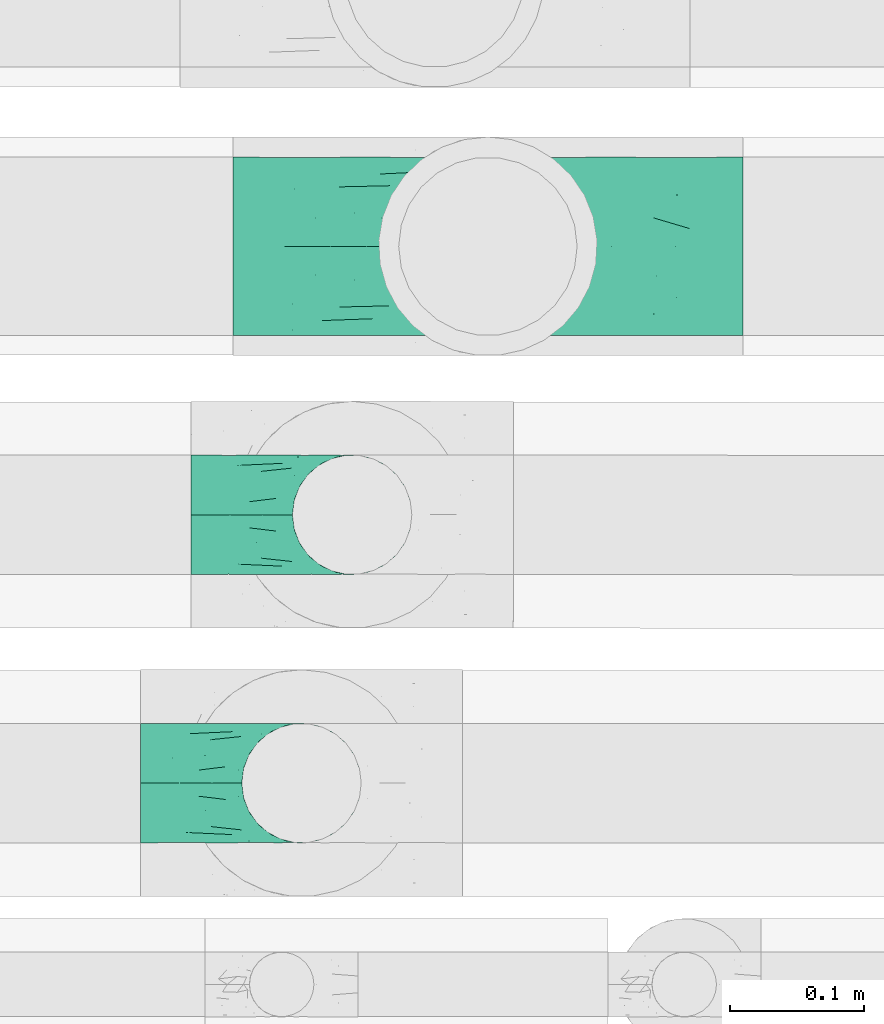
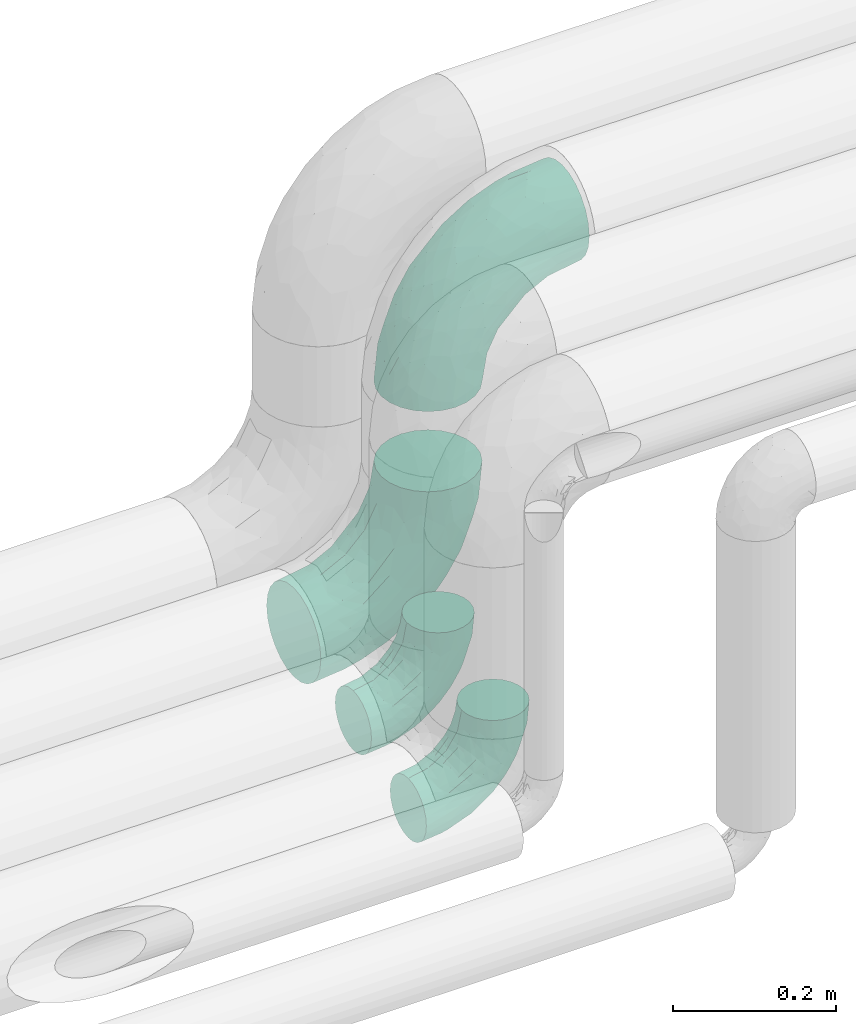
# One storey, part 58 of 93: 4 flow fittings.
"""IFC2X3 building model written with IfcOpenShell, lengths in millimetres."""

from ifc_helpers import new_model, entity, si_unit, converted_unit, derived_unit, direction, frame, origin, place, context, subcontext, project, spatial, faceted_brep, source, transform, mapped, material, type_object, type_shapes, element, save


model = new_model("IFC2X3")

# Units and contexts
model_context = context("Model", 3, precision=0.01, world=origin(), true_north=direction((6.12303176911189e-17, 1.0)))
body_context = subcontext(model_context, "Body", "Model", "MODEL_VIEW")
ifc_project = project(units=[si_unit("LENGTHUNIT", "METRE", prefix="MILLI"), si_unit("AREAUNIT", "SQUARE_METRE"), si_unit("VOLUMEUNIT", "CUBIC_METRE"), converted_unit("PLANEANGLEUNIT", "DEGREE", entity("IfcRatioMeasure", 0.0174532925199433), si_unit("PLANEANGLEUNIT", "RADIAN"), dimensions=[0, 0, 0, 0, 0, 0, 0]), si_unit("MASSUNIT", "GRAM", prefix="KILO"), derived_unit("MASSDENSITYUNIT", [(si_unit("MASSUNIT", "GRAM", prefix="KILO"), 1), (si_unit("LENGTHUNIT", "METRE"), -3)]), derived_unit("MOMENTOFINERTIAUNIT", [(si_unit("LENGTHUNIT", "METRE"), 4)]), si_unit("TIMEUNIT", "SECOND"), si_unit("FREQUENCYUNIT", "HERTZ"), si_unit("THERMODYNAMICTEMPERATUREUNIT", "DEGREE_CELSIUS"), derived_unit("THERMALTRANSMITTANCEUNIT", [(si_unit("MASSUNIT", "GRAM", prefix="KILO"), 1), (si_unit("THERMODYNAMICTEMPERATUREUNIT", "KELVIN"), -1), (si_unit("TIMEUNIT", "SECOND"), -3)]), derived_unit("VOLUMETRICFLOWRATEUNIT", [(si_unit("LENGTHUNIT", "METRE"), 3), (si_unit("TIMEUNIT", "SECOND"), -1)]), derived_unit("MASSFLOWRATEUNIT", [(si_unit("MASSUNIT", "GRAM", prefix="KILO"), 1), (si_unit("TIMEUNIT", "SECOND"), -1)]), derived_unit("ROTATIONALFREQUENCYUNIT", [(si_unit("TIMEUNIT", "SECOND"), -1)]), si_unit("ELECTRICCURRENTUNIT", "AMPERE"), si_unit("ELECTRICVOLTAGEUNIT", "VOLT"), si_unit("POWERUNIT", "WATT"), si_unit("FORCEUNIT", "NEWTON", prefix="KILO"), si_unit("ILLUMINANCEUNIT", "LUX"), si_unit("LUMINOUSFLUXUNIT", "LUMEN"), si_unit("LUMINOUSINTENSITYUNIT", "CANDELA"), derived_unit("USERDEFINED", [(si_unit("MASSUNIT", "GRAM", prefix="KILO"), -1), (si_unit("LENGTHUNIT", "METRE"), -2), (si_unit("TIMEUNIT", "SECOND"), 3), (si_unit("LUMINOUSFLUXUNIT", "LUMEN"), 1)]), derived_unit("LINEARVELOCITYUNIT", [(si_unit("LENGTHUNIT", "METRE"), 1), (si_unit("TIMEUNIT", "SECOND"), -1)]), si_unit("PRESSUREUNIT", "PASCAL"), derived_unit("USERDEFINED", [(si_unit("LENGTHUNIT", "METRE"), -2), (si_unit("MASSUNIT", "GRAM", prefix="KILO"), 1), (si_unit("TIMEUNIT", "SECOND"), -2)]), derived_unit("LINEARFORCEUNIT", [(si_unit("MASSUNIT", "GRAM", prefix="KILO"), 1), (si_unit("LENGTHUNIT", "METRE"), 1), (si_unit("TIMEUNIT", "SECOND"), -2), (si_unit("LENGTHUNIT", "METRE"), -1)]), derived_unit("PLANARFORCEUNIT", [(si_unit("MASSUNIT", "GRAM", prefix="KILO"), 1), (si_unit("LENGTHUNIT", "METRE"), 1), (si_unit("TIMEUNIT", "SECOND"), -2), (si_unit("LENGTHUNIT", "METRE"), -2)])], contexts=[model_context])

# Site, building, storey
site_placement = place(None, origin())
site = spatial("IfcSite", under=ifc_project, at=site_placement, CompositionType="ELEMENT")
building_placement = place(site_placement, origin())
building = spatial("IfcBuilding", under=site, at=building_placement, CompositionType="ELEMENT")
storey_placement = place(building_placement, frame((0.0, 0.0, -4200.0)))
storey = spatial("IfcBuildingStorey", under=building, at=storey_placement, CompositionType="ELEMENT", Elevation=-4200.0)

# Flow fittings
ifc_material = material()
pipe_fitting_type_1 = type_object("IfcPipeFittingType", Name="ADSK_2", PredefinedType="NOTDEFINED", material=ifc_material)
shared_shape_1 = source(origin(), body_context, "Body", "Brep", [
    faceted_brep([(-190.0, 33.25, -57.59), (-190.0, 17.21, -64.23), (-190.0, 0.0, -66.5), (-190.0, -17.21, -64.23), (-190.0, -33.25, -57.59), (-190.0, -47.02, -47.02), (-190.0, -57.59, -33.25), (-190.0, -64.23, -17.21), (-190.0, -66.5, 0.0), (-190.0, -64.23, 17.21), (-190.0, -57.59, 33.25), (-190.0, -47.02, 47.02), (-190.0, -33.25, 57.59), (-190.0, -17.21, 64.23), (-190.0, 0.0, 66.5), (-190.0, 17.21, 64.23), (-190.0, 33.25, 57.59), (-190.0, 47.02, 47.02), (-190.0, 57.59, 33.25), (-190.0, 64.23, 17.21), (-190.0, 66.5, 0.0), (-190.0, 64.23, -17.21), (-190.0, 57.59, -33.25), (-190.0, 47.02, -47.02), (0.0, 190.0, -66.5), (-17.21, 190.0, -64.23), (-33.25, 190.0, -57.59), (-47.02, 190.0, -47.02), (-57.59, 190.0, -33.25), (-64.23, 190.0, -17.21), (-66.5, 190.0, 0.0), (-64.23, 190.0, 17.21), (-57.59, 190.0, 33.25), (-47.02, 190.0, 47.02), (-33.25, 190.0, 57.59), (-17.21, 190.0, 64.23), (0.0, 190.0, 66.5), (17.21, 190.0, 64.23), (33.25, 190.0, 57.59), (47.02, 190.0, 47.02), (57.59, 190.0, 33.25), (64.23, 190.0, 17.21), (66.5, 190.0, 0.0), (64.23, 190.0, -17.21), (57.59, 190.0, -33.25), (47.02, 190.0, -47.02), (33.25, 190.0, -57.59), (17.21, 190.0, -64.23), (-28.55, 147.02, 62.42), (-13.57, 135.63, 66.28), (-140.38, -49.33, 38.23), (-80.14, -30.55, 35.23), (-124.14, -33.9, 50.4), (-141.11, -22.46, 60.31), (-81.84, -6.19, 57.13), (-101.3, 6.38, 65.03), (-125.04, -54.28, 21.95), (-139.96, -61.57, 0.0), (-30.59, -6.47, 21.28), (-47.5, -23.27, 0.0), (-8.63, 8.63, 0.0), (-101.64, 52.37, 61.01), (-147.02, 28.55, 62.42), (-107.01, 35.47, 64.88), (-72.79, -35.94, 16.05), (-91.84, -46.98, 0.0), (-42.05, -7.73, 34.33), (-4.24, 27.9, 35.0), (-46.26, 0.22, 45.96), (-148.38, -6.74, 65.57), (-135.63, 13.57, 66.28), (-58.81, 143.49, 42.9), (-64.43, 158.86, 27.32), (33.87, 124.03, 50.39), (-24.86, 95.88, 66.5), (-6.38, 101.3, 65.03), (-68.44, 29.45, 65.52), (-33.12, 50.38, 63.42), (-47.55, 58.11, 66.37), (-68.78, 157.93, 15.75), (-78.73, 128.81, 21.25), (-145.19, 58.3, 42.81), (-126.57, 73.12, 34.22), (-158.86, 64.43, 27.32), (-157.93, 68.78, 15.75), (-73.06, 126.96, 34.0), (-99.23, 99.23, 24.99), (-94.51, 94.51, 37.44), (-160.28, 41.89, 53.91), (-151.84, 72.54, 0.0), (-128.81, 78.73, 21.25), (-117.41, 90.09, 0.0), (7.42, 29.34, 16.05), (36.05, 72.53, 15.16), (23.27, 47.5, 0.0), (30.73, 80.34, 35.12), (61.57, 139.96, 0.0), (62.07, 150.38, 13.25), (46.98, 91.84, 0.0), (22.46, 141.08, 60.31), (6.16, 81.82, 57.15), (-39.4, 100.2, 64.86), (54.07, 123.33, 21.27), (49.32, 140.35, 38.22), (-83.36, -19.52, 48.87), (6.74, 148.38, 65.57), (-85.07, 81.39, 53.88), (-123.92, 51.92, 55.31), (-90.09, 117.41, 0.0), (-72.54, 151.84, 0.0), (-101.92, 101.92, 11.85), (-42.36, 157.28, 54.02), (-54.08, 118.94, 55.5), (-1.97, 47.81, 48.28), (22.27, 83.36, 46.49), (-79.1, 73.18, 59.88), (-73.69, 63.3, 64.01), (-96.26, 24.55, 66.5), (-73.56, 111.53, 44.32), (-111.08, 72.88, 45.21), (-31.39, 31.39, 56.96), (-71.89, 12.15, 62.21), (-42.48, 117.92, 61.28), (-157.28, 42.36, -54.02), (-72.79, -35.94, -16.05), (-44.48, -10.39, -33.14), (-30.59, -6.47, -21.28), (-101.3, 6.38, -65.03), (-148.38, -6.74, -65.57), (-135.63, 13.57, -66.28), (-157.93, 68.78, -15.75), (-128.81, 78.73, -21.25), (-158.86, 64.43, -27.32), (-147.02, 28.55, -62.42), (-100.2, 39.4, -64.86), (-95.88, 24.86, -66.5), (-150.3, -62.06, -13.27), (-101.92, 101.92, -11.85), (-143.49, 58.81, -42.9), (6.74, 148.38, -65.57), (-13.57, 135.63, -66.28), (-52.37, 101.64, -61.01), (-81.39, 85.07, -53.88), (-51.92, 123.92, -55.31), (-124.14, -33.9, -50.4), (-81.84, -6.19, -57.13), (-78.6, -18.73, -47.44), (-140.38, -49.33, -38.23), (-24.55, 96.26, -66.5), (-35.47, 107.01, -64.88), (-28.55, 147.02, -62.42), (-80.14, -30.55, -35.23), (-123.37, -54.04, -21.36), (-64.43, 158.86, -27.32), (-68.78, 157.93, -15.75), (-73.18, 79.1, -59.88), (-63.3, 73.69, -64.01), (-29.45, 68.44, -65.52), (-50.38, 33.12, -63.42), (-58.11, 47.55, -66.37), (-78.73, 128.81, -21.25), (-99.23, 99.23, -24.99), (-126.96, 73.06, -34.0), (-94.51, 94.51, -37.44), (-58.3, 145.19, -42.81), (-73.12, 126.57, -34.22), (-118.94, 54.08, -55.5), (-41.89, 160.28, -53.91), (22.46, 141.08, -60.31), (6.16, 81.82, -57.15), (-6.38, 101.3, -65.03), (33.87, 124.03, -50.39), (54.35, 125.32, -21.97), (35.86, 72.99, -16.69), (49.34, 140.46, -38.23), (7.54, 29.16, -15.21), (-141.11, -22.46, -60.31), (30.73, 80.34, -35.12), (22.8, 84.14, -46.35), (-4.38, 23.43, -29.89), (5.33, 47.62, -41.81), (-111.53, 73.56, -44.32), (-72.88, 111.08, -45.21), (-48.51, 2.91, -49.35), (-20.15, 28.66, -49.63), (-27.46, 10.86, -41.59), (-12.16, 71.91, -62.22), (2.48, 58.84, -50.8), (-117.92, 42.48, -61.28), (-31.39, 31.39, -56.96)], [[[0, 1, 2, 3, 4, 5, 6, 7, 8, 9, 10, 11, 12, 13, 14, 15, 16, 17, 18, 19, 20, 21, 22, 23]], [[24, 25, 26, 27, 28, 29, 30, 31, 32, 33, 34, 35, 36, 37, 38, 39, 40, 41, 42, 43, 44, 45, 46, 47]], [[35, 48, 49]], [[50, 51, 52]], [[53, 54, 55]], [[56, 10, 9]], [[9, 8, 57]], [[58, 59, 60]], [[56, 50, 10]], [[61, 62, 63]], [[64, 65, 59]], [[58, 64, 59]], [[12, 11, 52]], [[66, 67, 68]], [[52, 53, 12]], [[69, 70, 14]], [[71, 32, 72]], [[73, 39, 38]], [[49, 74, 75]], [[62, 16, 15]], [[14, 70, 15]], [[72, 32, 31]], [[13, 69, 14]], [[76, 77, 78]], [[79, 80, 72]], [[81, 82, 83]], [[62, 15, 70]], [[20, 19, 84]], [[85, 86, 87]], [[81, 17, 88]], [[89, 90, 91]], [[19, 83, 84]], [[16, 88, 17]], [[85, 71, 72]], [[58, 60, 92]], [[49, 36, 35]], [[93, 92, 94]], [[35, 34, 48]], [[92, 93, 95]], [[96, 97, 98]], [[73, 99, 100]], [[49, 101, 74]], [[102, 97, 40]], [[39, 73, 103]], [[95, 102, 103]], [[40, 39, 103]], [[12, 53, 13]], [[68, 54, 104]], [[42, 97, 96]], [[41, 97, 42]], [[99, 38, 37]], [[37, 36, 105]], [[61, 106, 107]], [[108, 80, 109]], [[10, 50, 11]], [[108, 91, 110]], [[109, 79, 30]], [[64, 51, 56]], [[71, 33, 32]], [[86, 110, 90]], [[92, 60, 94]], [[111, 34, 33]], [[71, 112, 111]], [[49, 48, 101]], [[9, 57, 56]], [[17, 81, 18]], [[65, 56, 57]], [[113, 114, 100]], [[75, 105, 49]], [[115, 61, 116]], [[58, 92, 67]], [[99, 73, 38]], [[70, 117, 63]], [[18, 83, 19]], [[71, 85, 118]], [[119, 107, 106]], [[83, 82, 90]], [[51, 50, 56]], [[52, 11, 50]], [[51, 64, 58]], [[56, 65, 64]], [[94, 98, 93]], [[67, 92, 95]], [[95, 114, 113]], [[68, 120, 54]], [[54, 53, 52]], [[69, 53, 55]], [[104, 51, 68]], [[121, 76, 55]], [[103, 73, 114]], [[102, 40, 103]], [[105, 99, 37]], [[75, 77, 100]], [[75, 100, 99]], [[100, 120, 113]], [[111, 48, 34]], [[115, 101, 122]], [[122, 101, 48]], [[101, 116, 78]], [[116, 63, 117]], [[78, 117, 76]], [[63, 62, 70]], [[88, 62, 107]], [[98, 102, 93]], [[95, 93, 102]], [[66, 68, 51]], [[113, 68, 67]], [[49, 105, 36]], [[99, 105, 75]], [[53, 69, 13]], [[70, 69, 55]], [[70, 55, 117]], [[61, 63, 116]], [[76, 117, 55]], [[116, 117, 78]], [[121, 55, 54]], [[76, 121, 77]], [[100, 77, 120]], [[75, 78, 77]], [[54, 120, 121]], [[77, 121, 120]], [[71, 111, 33]], [[111, 112, 122]], [[68, 113, 120]], [[95, 113, 67]], [[61, 115, 106]], [[62, 61, 107]], [[118, 112, 71]], [[119, 87, 82]], [[101, 115, 116]], [[112, 106, 115]], [[79, 72, 31]], [[72, 80, 85]], [[86, 85, 80]], [[118, 85, 87]], [[119, 118, 87]], [[112, 118, 106]], [[30, 79, 31]], [[109, 80, 79]], [[81, 83, 18]], [[84, 83, 90]], [[119, 82, 81]], [[86, 82, 87]], [[107, 119, 81]], [[118, 119, 106]], [[90, 89, 84]], [[20, 84, 89]], [[62, 88, 16]], [[81, 88, 107]], [[101, 78, 74]], [[78, 75, 74]], [[80, 108, 110]], [[82, 86, 90]], [[90, 110, 91]], [[80, 110, 86]], [[40, 97, 41]], [[98, 97, 102]], [[111, 122, 48]], [[115, 122, 112]], [[54, 52, 104]], [[51, 104, 52]], [[51, 58, 66]], [[67, 66, 58]], [[103, 114, 95]], [[100, 114, 73]], [[23, 123, 0]], [[124, 125, 126]], [[127, 128, 129]], [[130, 131, 132]], [[133, 134, 129]], [[129, 135, 127]], [[89, 130, 20]], [[8, 136, 57]], [[91, 131, 89]], [[59, 65, 124]], [[108, 137, 91]], [[132, 22, 21]], [[138, 23, 22]], [[139, 140, 24]], [[141, 142, 143]], [[144, 145, 146]], [[5, 144, 147]], [[140, 148, 149]], [[8, 7, 136]], [[138, 22, 132]], [[6, 5, 147]], [[141, 150, 149]], [[147, 151, 152]], [[152, 136, 6]], [[29, 153, 154]], [[125, 124, 151]], [[136, 65, 57]], [[155, 141, 156]], [[128, 3, 2]], [[126, 59, 124]], [[129, 134, 135]], [[157, 158, 159]], [[160, 161, 137]], [[1, 0, 133]], [[129, 2, 1]], [[162, 138, 132]], [[161, 163, 162]], [[154, 30, 29]], [[144, 5, 4]], [[153, 164, 165]], [[150, 26, 25]], [[166, 123, 138]], [[24, 47, 139]], [[24, 140, 25]], [[28, 153, 29]], [[26, 167, 27]], [[168, 169, 170]], [[140, 150, 25]], [[27, 164, 28]], [[46, 171, 168]], [[172, 98, 173]], [[59, 126, 60]], [[27, 167, 164]], [[44, 174, 45]], [[173, 98, 94]], [[175, 173, 94]], [[176, 144, 4]], [[171, 46, 45]], [[44, 43, 172]], [[43, 96, 172]], [[42, 96, 43]], [[144, 146, 151]], [[144, 176, 145]], [[177, 178, 174]], [[173, 175, 179]], [[44, 172, 174]], [[98, 172, 96]], [[1, 133, 129]], [[179, 180, 177]], [[109, 160, 108]], [[46, 168, 47]], [[176, 4, 3]], [[138, 162, 181]], [[182, 143, 142]], [[153, 165, 160]], [[94, 60, 175]], [[177, 172, 173]], [[151, 147, 144]], [[152, 6, 147]], [[128, 176, 3]], [[127, 158, 145]], [[127, 145, 176]], [[183, 184, 185]], [[65, 152, 124]], [[151, 124, 152]], [[177, 174, 172]], [[171, 45, 174]], [[169, 168, 171]], [[139, 168, 170]], [[178, 177, 180]], [[186, 157, 170]], [[187, 169, 178]], [[126, 179, 175]], [[123, 133, 0]], [[155, 134, 188]], [[188, 134, 133]], [[134, 156, 159]], [[156, 149, 148]], [[159, 148, 157]], [[149, 150, 140]], [[167, 150, 143]], [[60, 126, 175]], [[125, 179, 126]], [[129, 128, 2]], [[176, 128, 127]], [[168, 139, 47]], [[140, 139, 170]], [[140, 170, 148]], [[141, 149, 156]], [[157, 148, 170]], [[156, 148, 159]], [[186, 170, 169]], [[157, 186, 158]], [[145, 158, 189]], [[127, 159, 158]], [[169, 189, 186]], [[158, 186, 189]], [[180, 179, 185]], [[173, 179, 177]], [[187, 184, 189]], [[178, 171, 174]], [[187, 178, 180]], [[169, 171, 178]], [[184, 180, 185]], [[189, 169, 187]], [[138, 123, 23]], [[123, 166, 188]], [[141, 155, 142]], [[150, 141, 143]], [[181, 166, 138]], [[182, 163, 165]], [[134, 155, 156]], [[166, 142, 155]], [[130, 132, 21]], [[132, 131, 162]], [[161, 162, 131]], [[181, 162, 163]], [[182, 181, 163]], [[166, 181, 142]], [[20, 130, 21]], [[89, 131, 130]], [[164, 153, 28]], [[154, 153, 160]], [[182, 165, 164]], [[161, 165, 163]], [[143, 182, 164]], [[181, 182, 142]], [[160, 109, 154]], [[30, 154, 109]], [[150, 167, 26]], [[164, 167, 143]], [[134, 159, 135]], [[159, 127, 135]], [[131, 91, 137]], [[165, 161, 160]], [[160, 137, 108]], [[131, 137, 161]], [[6, 136, 7]], [[65, 136, 152]], [[183, 189, 184]], [[146, 183, 125]], [[146, 125, 151]], [[179, 125, 185]], [[123, 188, 133]], [[155, 188, 166]], [[180, 184, 187]], [[185, 125, 183]], [[146, 145, 183]], [[189, 183, 145]]]),
])
type_shapes(pipe_fitting_type_1, [shared_shape_1])
for number, where, z_axis, x_axis, name in (
    (1, (-1852.18, 14300.0, 3000.0), (0.0, 1.0, 0.0), (0.0, 0.0, 1.0), "ADSK_2"),
    (2, (-1852.18, 14300.0, 2500.0), (0.0, 1.0, 0.0), (0.0, 0.0, -1.0), "ADSK_2"),
):
    element("IfcFlowFitting", number, at=place(storey_placement, frame(where, z_axis=z_axis, x_axis=x_axis)), inside=storey, type_object=pipe_fitting_type_1, material=ifc_material, Name=name, ObjectType="ADSK_2", context=body_context, shape_type="MappedRepresentation", body=[
        mapped(shared_shape_1, transform((0.0, 0.0, 0.0), scale=1.0)),
    ])
pipe_fitting_type_2 = type_object("IfcPipeFittingType", Name="ADSK_2", PredefinedType="NOTDEFINED", material=ifc_material)
shared_shape_2 = source(origin(), body_context, "Body", "Brep", [
    faceted_brep([(-120.0, 22.25, -38.54), (-120.0, 11.52, -42.98), (-120.0, 0.0, -44.5), (-120.0, -11.52, -42.98), (-120.0, -22.25, -38.54), (-120.0, -31.47, -31.47), (-120.0, -38.54, -22.25), (-120.0, -42.98, -11.52), (-120.0, -44.5, 0.0), (-120.0, -42.98, 11.52), (-120.0, -38.54, 22.25), (-120.0, -31.47, 31.47), (-120.0, -22.25, 38.54), (-120.0, -11.52, 42.98), (-120.0, 0.0, 44.5), (-120.0, 11.52, 42.98), (-120.0, 22.25, 38.54), (-120.0, 31.47, 31.47), (-120.0, 38.54, 22.25), (-120.0, 42.98, 11.52), (-120.0, 44.5, 0.0), (-120.0, 42.98, -11.52), (-120.0, 38.54, -22.25), (-120.0, 31.47, -31.47), (0.0, 120.0, -44.5), (-11.52, 120.0, -42.98), (-22.25, 120.0, -38.54), (-31.47, 120.0, -31.47), (-38.54, 120.0, -22.25), (-42.98, 120.0, -11.52), (-44.5, 120.0, 0.0), (-42.98, 120.0, 11.52), (-38.54, 120.0, 22.25), (-31.47, 120.0, 31.47), (-22.25, 120.0, 38.54), (-11.52, 120.0, 42.98), (0.0, 120.0, 44.5), (11.52, 120.0, 42.98), (22.25, 120.0, 38.54), (31.47, 120.0, 31.47), (38.54, 120.0, 22.25), (42.98, 120.0, 11.52), (44.5, 120.0, 0.0), (42.98, 120.0, -11.52), (38.54, 120.0, -22.25), (31.47, 120.0, -31.47), (22.25, 120.0, -38.54), (11.52, 120.0, -42.98), (-20.51, 85.66, 41.98), (-29.31, 93.55, 36.45), (-98.0, -41.6, 0.0), (-80.92, -37.22, 14.68), (-66.68, -9.63, 39.67), (-84.59, -24.55, 33.9), (-50.35, -12.87, 32.85), (-77.42, -38.89, 0.0), (-22.01, -9.62, 13.21), (-37.75, -22.46, 0.0), (-20.72, -9.39, 0.0), (-89.18, -33.47, 25.4), (12.87, 50.35, 32.85), (24.55, 84.59, 33.9), (9.63, 66.68, 39.67), (-49.55, -27.06, 11.21), (-28.67, -9.99, 21.67), (-52.01, -22.41, 23.47), (-95.53, -16.28, 40.49), (-86.01, -3.42, 43.77), (22.41, 52.01, 23.47), (9.05, 21.37, 13.44), (26.5, 49.37, 12.73), (33.47, 89.18, 25.4), (37.22, 80.92, 14.68), (16.28, 95.53, 40.49), (3.42, 86.01, 43.77), (-7.84, 52.6, 43.16), (-84.39, 31.88, 36.84), (-30.52, 34.28, 44.33), (-21.99, 28.55, 42.22), (-93.56, 38.23, 28.63), (-65.04, 31.74, 41.51), (-91.98, 19.0, 41.83), (-34.03, 70.24, 39.41), (-96.36, 44.0, 18.64), (-98.49, 46.74, 8.65), (-76.5, 56.97, 9.76), (-4.96, 4.47, 11.32), (-7.16, 6.18, 18.93), (-56.62, 75.93, 12.18), (-66.61, 66.61, 0.0), (-92.12, 7.25, 44.33), (-7.23, 92.66, 44.32), (30.68, 57.59, 0.0), (-44.45, 94.8, 18.75), (-36.39, 101.98, 28.14), (-46.83, 97.45, 9.69), (-38.03, 47.61, 43.21), (-24.7, 65.7, 43.29), (41.6, 98.0, 0.0), (-54.11, 72.8, 21.53), (-47.95, 9.75, 42.93), (-18.65, 18.65, 37.89), (-91.11, 50.25, 0.0), (-50.25, 91.11, 0.0), (-57.59, -30.68, 0.0), (-44.16, 67.2, 34.92), (-55.15, 62.16, 29.74), (-68.1, 47.21, 32.31), (-51.09, 51.09, 38.36), (-16.69, 62.62, 44.46), (-58.26, 18.84, 44.48), (-71.55, 55.71, 20.49), (-43.13, 80.04, 29.45), (-37.23, 0.88, 36.78), (-18.15, 10.22, 33.09), (5.51, 28.08, 26.74), (-3.68, 3.68, 0.0), (9.39, 20.72, 0.0), (-2.58, 27.98, 33.59), (-2.38, 41.22, 38.93), (-16.09, 4.55, 27.06), (38.89, 77.42, 0.0), (22.46, 37.75, 0.0), (-92.66, 7.23, -44.32), (-22.01, -9.62, -13.21), (-49.81, -26.66, -12.91), (-28.67, -9.99, -21.67), (-62.62, 16.69, -44.46), (-65.04, 31.74, -41.51), (-38.89, 47.26, -43.11), (-56.62, 75.93, -12.18), (-93.56, 38.23, -28.63), (-84.39, 31.88, -36.84), (16.28, 95.53, -40.49), (3.42, 86.01, -43.77), (-98.49, 46.74, -8.65), (-44.45, 94.8, -18.75), (-54.11, 72.8, -21.53), (-76.5, 56.97, -9.76), (24.55, 84.59, -33.9), (9.63, 66.68, -39.67), (-96.36, 44.0, -18.64), (-29.4, 93.16, -36.47), (-91.98, 19.0, -41.83), (-80.92, -37.22, -14.68), (-52.6, 7.84, -43.16), (-86.01, -3.42, -43.77), (-89.18, -33.47, -25.4), (-52.01, -22.41, -23.47), (-50.35, -12.87, -32.85), (-84.59, -24.55, -33.9), (-66.68, -9.63, -39.67), (-95.53, -16.28, -40.49), (-68.1, 47.21, -32.31), (-35.81, 11.1, -40.85), (-19.61, 28.53, -41.59), (-18.65, 18.65, -37.89), (-4.97, 4.47, -11.34), (9.05, 21.37, -13.44), (-34.28, 30.52, -44.33), (-9.75, 47.95, -42.93), (-2.58, 27.98, -33.59), (-18.15, 10.22, -33.09), (-46.83, 97.45, -9.69), (12.87, 50.35, -32.85), (26.8, 49.13, -11.4), (-7.34, 92.03, -44.33), (-21.02, 83.86, -42.03), (-44.6, 66.82, -34.8), (-55.46, 62.18, -29.47), (37.22, 80.92, -14.68), (33.47, 89.18, -25.4), (-34.39, 70.11, -39.28), (-25.04, 64.41, -43.37), (-18.84, 58.26, -44.48), (22.41, 52.01, -23.47), (-36.39, 101.98, -28.14), (-51.09, 51.09, -38.36), (-43.13, 80.04, -29.45), (-71.55, 55.71, -20.49), (-7.15, 6.2, -18.94), (5.51, 28.08, -26.74), (-37.23, 0.88, -36.78), (-2.38, 41.22, -38.93), (-16.09, 4.55, -27.06)], [[[0, 1, 2, 3, 4, 5, 6, 7, 8, 9, 10, 11, 12, 13, 14, 15, 16, 17, 18, 19, 20, 21, 22, 23]], [[24, 25, 26, 27, 28, 29, 30, 31, 32, 33, 34, 35, 36, 37, 38, 39, 40, 41, 42, 43, 44, 45, 46, 47]], [[48, 34, 49]], [[50, 51, 9]], [[52, 53, 54]], [[9, 51, 10]], [[55, 51, 50]], [[56, 57, 58]], [[51, 59, 10]], [[60, 61, 62]], [[63, 64, 65]], [[13, 12, 66]], [[67, 14, 13]], [[68, 69, 70]], [[71, 68, 72]], [[38, 73, 61]], [[74, 75, 62]], [[17, 16, 76]], [[77, 78, 75]], [[79, 18, 17]], [[80, 76, 81]], [[35, 34, 48]], [[49, 82, 48]], [[18, 83, 19]], [[16, 81, 76]], [[20, 19, 84]], [[85, 84, 83]], [[56, 86, 87]], [[85, 88, 89]], [[37, 36, 74]], [[90, 14, 67]], [[79, 17, 76]], [[63, 65, 51]], [[13, 66, 67]], [[61, 39, 38]], [[91, 74, 36]], [[70, 92, 72]], [[93, 94, 32]], [[95, 88, 93]], [[62, 73, 74]], [[82, 96, 97]], [[40, 72, 41]], [[72, 68, 70]], [[71, 72, 40]], [[34, 33, 49]], [[72, 98, 41]], [[99, 93, 88]], [[71, 39, 61]], [[78, 100, 101]], [[85, 89, 102]], [[53, 52, 66]], [[103, 95, 30]], [[12, 11, 53]], [[103, 89, 88]], [[104, 57, 63]], [[91, 48, 97]], [[93, 32, 31]], [[33, 32, 94]], [[16, 15, 81]], [[105, 106, 107]], [[76, 107, 79]], [[35, 91, 36]], [[80, 96, 108]], [[31, 95, 93]], [[65, 53, 59]], [[73, 38, 37]], [[75, 74, 109]], [[61, 60, 68]], [[11, 10, 59]], [[54, 53, 65]], [[100, 67, 52]], [[110, 81, 90]], [[15, 14, 90]], [[76, 80, 108]], [[107, 76, 108]], [[83, 79, 111]], [[94, 49, 33]], [[82, 105, 108]], [[84, 85, 102]], [[111, 88, 85]], [[99, 88, 111]], [[94, 93, 112]], [[48, 91, 35]], [[74, 91, 109]], [[69, 87, 86]], [[113, 54, 114]], [[64, 56, 87]], [[60, 115, 68]], [[116, 117, 86]], [[69, 68, 115]], [[79, 83, 18]], [[85, 83, 111]], [[81, 110, 80]], [[110, 77, 96]], [[110, 96, 80]], [[97, 96, 109]], [[107, 108, 105]], [[111, 79, 107]], [[77, 75, 109]], [[118, 119, 101]], [[96, 77, 109]], [[77, 110, 100]], [[67, 100, 110]], [[100, 52, 113]], [[60, 119, 118]], [[118, 120, 115]], [[64, 54, 65]], [[114, 120, 118]], [[118, 115, 60]], [[115, 120, 87]], [[74, 73, 37]], [[61, 73, 62]], [[53, 66, 12]], [[67, 66, 52]], [[110, 90, 67]], [[15, 90, 81]], [[105, 49, 112]], [[96, 82, 108]], [[119, 60, 62]], [[118, 101, 114]], [[62, 75, 119]], [[78, 119, 75]], [[49, 105, 82]], [[105, 112, 106]], [[99, 112, 93]], [[111, 107, 106]], [[113, 114, 101]], [[54, 120, 114]], [[100, 113, 101]], [[52, 54, 113]], [[20, 84, 102]], [[83, 84, 19]], [[111, 106, 99]], [[112, 99, 106]], [[100, 78, 77]], [[119, 78, 101]], [[39, 71, 40]], [[68, 71, 61]], [[65, 59, 51]], [[11, 59, 53]], [[30, 95, 31]], [[103, 88, 95]], [[9, 8, 50]], [[98, 72, 121]], [[98, 42, 41]], [[49, 94, 112]], [[56, 63, 57]], [[51, 55, 104]], [[92, 121, 72]], [[86, 58, 116]], [[54, 64, 120]], [[115, 87, 69]], [[120, 64, 87]], [[58, 86, 56]], [[86, 117, 69]], [[91, 97, 109]], [[122, 69, 117]], [[82, 97, 48]], [[63, 56, 64]], [[104, 63, 51]], [[69, 122, 70]], [[92, 70, 122]], [[123, 2, 1]], [[124, 125, 126]], [[127, 128, 129]], [[103, 130, 89]], [[23, 131, 132]], [[47, 133, 134]], [[102, 135, 20]], [[130, 136, 137]], [[102, 138, 135]], [[139, 140, 133]], [[22, 21, 141]], [[27, 26, 142]], [[46, 45, 139]], [[0, 143, 1]], [[6, 144, 7]], [[145, 146, 127]], [[144, 50, 7]], [[147, 148, 144]], [[144, 6, 147]], [[149, 150, 151]], [[4, 3, 152]], [[23, 22, 131]], [[132, 131, 153]], [[43, 42, 98]], [[125, 104, 144]], [[154, 155, 156]], [[146, 151, 152]], [[4, 150, 5]], [[123, 146, 2]], [[157, 158, 117]], [[130, 138, 89]], [[29, 28, 136]], [[159, 160, 155]], [[161, 162, 156]], [[89, 138, 102]], [[163, 30, 29]], [[164, 140, 139]], [[163, 136, 130]], [[23, 132, 0]], [[158, 165, 122]], [[25, 24, 166]], [[0, 132, 143]], [[4, 152, 150]], [[142, 26, 167]], [[3, 2, 146]], [[167, 26, 25]], [[133, 47, 46]], [[168, 153, 169]], [[146, 145, 151]], [[149, 126, 148]], [[44, 170, 171]], [[24, 47, 134]], [[170, 44, 43]], [[144, 148, 125]], [[170, 98, 121]], [[168, 142, 172]], [[129, 173, 174]], [[98, 170, 43]], [[147, 5, 150]], [[157, 58, 124]], [[92, 122, 165]], [[134, 166, 24]], [[175, 139, 171]], [[28, 27, 176]], [[29, 136, 163]], [[132, 128, 143]], [[45, 44, 171]], [[164, 139, 175]], [[160, 134, 140]], [[174, 173, 166]], [[141, 131, 22]], [[132, 153, 177]], [[128, 132, 177]], [[123, 143, 127]], [[172, 142, 167]], [[176, 142, 178]], [[130, 179, 138]], [[138, 179, 141]], [[176, 136, 28]], [[130, 137, 179]], [[174, 166, 134]], [[167, 25, 166]], [[143, 123, 1]], [[146, 123, 127]], [[150, 149, 148]], [[157, 124, 180]], [[181, 161, 164]], [[181, 158, 180]], [[124, 126, 180]], [[170, 165, 175]], [[141, 21, 135]], [[131, 141, 179]], [[131, 179, 153]], [[179, 137, 169]], [[129, 128, 177]], [[127, 143, 128]], [[129, 177, 172]], [[129, 174, 159]], [[159, 145, 127]], [[182, 154, 156]], [[129, 159, 127]], [[159, 174, 160]], [[134, 160, 174]], [[140, 164, 183]], [[162, 182, 156]], [[126, 149, 184]], [[181, 164, 175]], [[164, 161, 183]], [[158, 181, 175]], [[184, 162, 161]], [[146, 152, 3]], [[150, 152, 151]], [[139, 133, 46]], [[134, 133, 140]], [[184, 161, 181]], [[161, 156, 183]], [[155, 183, 156]], [[160, 140, 183]], [[184, 149, 162]], [[182, 162, 149]], [[149, 151, 182]], [[154, 151, 145]], [[151, 154, 182]], [[159, 154, 145]], [[159, 155, 154]], [[183, 155, 160]], [[141, 135, 138]], [[20, 135, 21]], [[136, 178, 137]], [[169, 178, 168]], [[172, 167, 173]], [[168, 172, 177]], [[153, 168, 177]], [[142, 168, 178]], [[179, 169, 153]], [[137, 178, 169]], [[5, 147, 6]], [[148, 147, 150]], [[175, 171, 170]], [[45, 171, 139]], [[130, 103, 163]], [[30, 163, 103]], [[50, 144, 55]], [[50, 8, 7]], [[142, 176, 27]], [[136, 176, 178]], [[126, 125, 148]], [[104, 55, 144]], [[170, 121, 92]], [[58, 57, 124]], [[180, 126, 184]], [[181, 180, 184]], [[180, 158, 157]], [[158, 122, 117]], [[58, 157, 116]], [[172, 173, 129]], [[116, 157, 117]], [[166, 173, 167]], [[124, 57, 125]], [[104, 125, 57]], [[175, 165, 158]], [[92, 165, 170]]]),
])
type_shapes(pipe_fitting_type_2, [shared_shape_2])
for number, where, z_axis, x_axis, name in (
    (3, (-1953.35, 14100.0, 2500.3), (0.0, -1.0, 0.0), (1.0, 0.0, 0.0), "ADSK_2"),
    (4, (-1991.09, 13900.0, 2503.64), (0.0, -1.0, 0.0), (1.0, 0.0, 0.0), "ADSK_2"),
):
    element("IfcFlowFitting", number, at=place(storey_placement, frame(where, z_axis=z_axis, x_axis=x_axis)), inside=storey, type_object=pipe_fitting_type_2, material=ifc_material, Name=name, ObjectType="ADSK_2", context=body_context, shape_type="MappedRepresentation", body=[
        mapped(shared_shape_2, transform((0.0, 0.0, 0.0), scale=1.0)),
    ])

save(model, "model.ifc")
